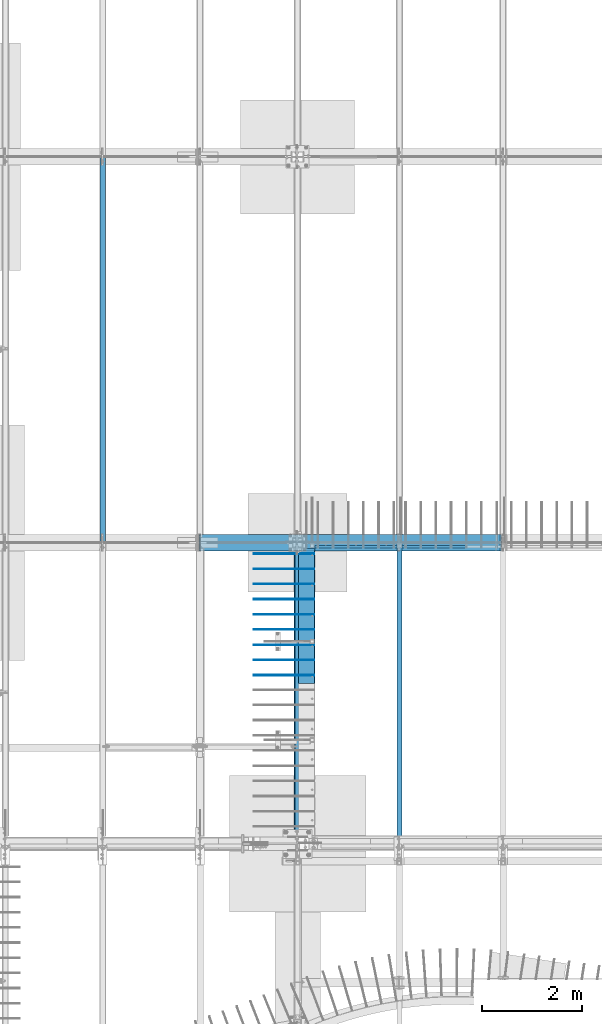
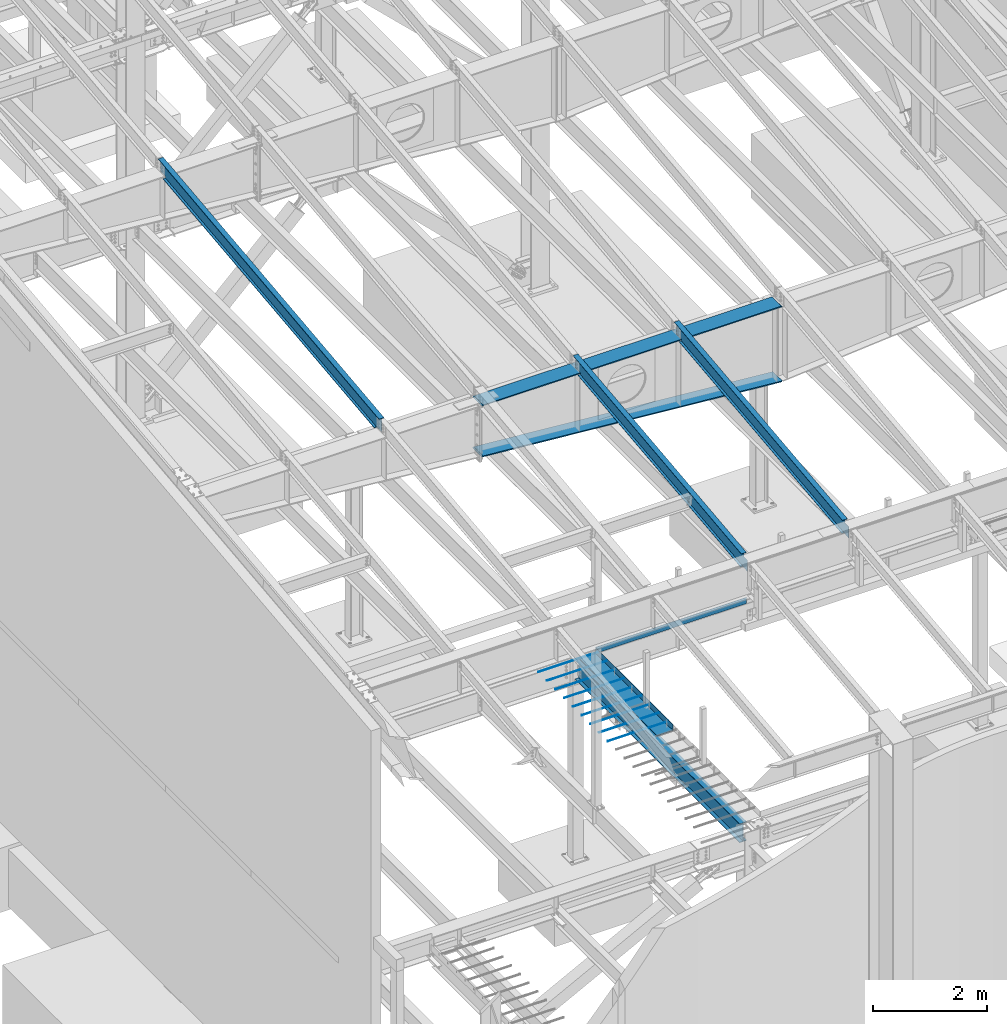
# One storey, part 710 of 1179: 17 beams, 15 elements without a shape of their own.
"""IFC2X3 building model written with IfcOpenShell, lengths in millimetres."""

from ifc_helpers import new_model, si_unit, frame, origin_with_axes, place, context, subcontext, project, spatial, faceted_brep, material, type_object, element, aggregate, save


model = new_model("IFC2X3")

# Units and contexts
model_context = context("Model", 3, precision=1e-05, world=origin_with_axes())
body_context = subcontext(model_context, "Body", "Model", "MODEL_VIEW")
ifc_project = project(units=[si_unit("LENGTHUNIT", "METRE", prefix="MILLI"), si_unit("AREAUNIT", "SQUARE_METRE"), si_unit("VOLUMEUNIT", "CUBIC_METRE"), si_unit("MASSUNIT", "GRAM", prefix="KILO"), si_unit("TIMEUNIT", "SECOND"), si_unit("PLANEANGLEUNIT", "RADIAN"), si_unit("SOLIDANGLEUNIT", "STERADIAN"), si_unit("THERMODYNAMICTEMPERATUREUNIT", "DEGREE_CELSIUS"), si_unit("LUMINOUSINTENSITYUNIT", "LUMEN")], contexts=[model_context])

# Site, building, storey
site_placement = place(None, origin_with_axes())
site = spatial("IfcSite", under=ifc_project, at=site_placement, CompositionType="ELEMENT")
building_placement = place(site_placement, origin_with_axes())
building = spatial("IfcBuilding", under=site, at=building_placement, Name="Undefined", CompositionType="ELEMENT")
storey_placement = place(building_placement, origin_with_axes())
storey = spatial("IfcBuildingStorey", under=building, at=storey_placement, Name="Undefined", CompositionType="ELEMENT", Elevation=0.0)

# Assembly, beam
assembly_1_placement = place(storey_placement, origin_with_axes())
assembly_1 = element("IfcElementAssembly", 1, at=assembly_1_placement, inside=storey, Name="BEAM", AssemblyPlace="NOTDEFINED", PredefinedType="RIGID_FRAME")
ifc_material_1 = material(Name="STEEL/A36")
beam_type_1 = type_object("IfcBeamType", PredefinedType="NOTDEFINED")
beam_1_placement = place(assembly_1_placement, frame((10150.475, 11372.85, 4235.45000610352), z_axis=(1.0, 0.0, 0.0), x_axis=(0.0, 0.0, -1.0)))
beam_1 = element("IfcBeam", 2, at=beam_1_placement, type_object=beam_type_1, material=ifc_material_1, Name="BENT_PLATE", context=body_context, shape_type="Brep", body=[
    faceted_brep([(133.350006103517, 47.6249992370613, 123.824999999997), (127.000006103516, 47.6249992370613, 123.824999999997), (127.000006103516, 3.17499999999927, 123.824999999997), (133.350006103517, 3.17499965729257, 123.824999999997), (133.350006103517, 3.17499965729257, 225.424999999999), (127.000006103516, 3.17499999999927, 225.424999999999), (127.000006103516, 47.6249992370613, 225.424999999999), (133.350006103517, 47.6249992370613, 225.424999999999), (0.0, 3.17499999999927, 123.824999999997), (0.0, 3.17499999999927, -1524.0), (0.0, -3.17499999999927, -1524.0), (6.00266503170133e-10, -3.17499999922438, 1524.00000000052), (6.00266503170133e-10, 3.17500000077416, 1524.00000000052), (0.0, 3.17499999999927, 225.424999999999), (133.350006103517, -3.17499999999927, -1524.0), (127.000006103516, 3.17499999999927, -1524.0), (127.000006103516, 47.6249992370613, -1524.0), (133.350006103517, 47.6249992370613, -1524.0), (133.350006103517, -3.17499999999927, 1524.0), (127.000006103516, 3.17499999999927, 1524.0), (133.350006103517, 47.6249992370613, 1524.0), (127.000006103516, 47.6249992370613, 1524.0)], [[[0, 1, 2, 3]], [[4, 5, 6, 7]], [[3, 2, 5, 4]], [[8, 9, 10, 11, 12, 13]], [[14, 10, 9, 15, 16, 17]], [[11, 10, 14, 18]], [[19, 12, 11, 18, 20, 21]], [[21, 20, 7, 6]], [[19, 21, 6, 5]], [[9, 8, 13, 12, 19, 5, 2, 15]], [[16, 15, 2, 1]], [[17, 16, 1, 0]], [[20, 18, 14, 17, 0, 3, 4, 7]]]),
])
aggregate(assembly_1, [beam_1])

assembly_2_placement = place(storey_placement, origin_with_axes())
assembly_2 = element("IfcElementAssembly", 3, at=assembly_2_placement, inside=storey, Name="BEAM", AssemblyPlace="NOTDEFINED", PredefinedType="RIGID_FRAME")
ifc_material_2 = material(Name="STEEL/A992")
beam_type_2 = type_object("IfcBeamType", Name="W12X14", PredefinedType="NOTDEFINED")
beam_2_placement = place(assembly_2_placement, frame((10325.1, 5452.54317924679, 9711.23798851527), z_axis=(0.0, -0.112284087038017, 0.993676146336441), x_axis=(0.0, 0.993676146336441, 0.112284087038017)))
beam_2 = element("IfcBeam", 4, at=beam_2_placement, type_object=beam_type_2, material=ifc_material_2, Name="BEAM", ObjectType="W12X14", context=body_context, shape_type="Brep", body=[
    faceted_brep([(-14.1944481268274, -2.38125000000036, -144.462499999927), (-14.9119897074661, -2.38115214811296, -150.812499999925), (137.488001223044, -2.38117577009325, -150.8125), (137.488001223013, -2.38125000000036, -144.462500000003), (137.48799371822, -50.7999999999993, -144.462500000005), (137.487993718216, -50.7999999999993, -150.812500000002), (5871.37503272929, 50.7999999999993, -144.462500002917), (5870.65749114864, 50.7999999999993, -150.812500002912), (137.488009517103, 50.7999999999993, -150.812500000002), (137.488009517107, 50.7999999999993, -144.462500000003), (137.488002012233, 2.3811758245356, -144.462500001737), (137.488002012265, 2.38132415558357, -150.812500000002), (-14.9119897074661, 2.38134777762207, -150.812499999925), (-14.1944481268274, 2.38125000000036, -144.462499999927), (5871.37503272928, 2.38124783346939, -144.462500002968), (6076.55490468175, 2.38124999999854, 144.462499996846), (6076.55490468175, 50.7999999999993, 144.462499996846), (6077.27244626239, 50.7999999999993, 150.812499996842), (6077.27244626239, -50.7999999999993, 150.812499996842), (6076.55490468175, -50.7999999999993, 144.462499996846), (6076.55490468175, -2.38124999999854, 144.462499996846), (6045.98095926941, -2.38124999999854, -126.106563095373), (6045.98095929506, 2.38124999999854, -126.10656309827), (5888.24414721426, -2.38124999999854, -108.282512497075), (5888.24414721426, 2.38122772319184, -108.282512497075), (5883.30625374162, -2.38124999999854, -108.697419370077), (5883.30625374162, 2.38122766974266, -108.697419370077), (5878.90301301472, -2.38124999999854, -110.970393360541), (5878.90301301472, 2.38122737693629, -110.970393360541), (5875.70477851863, -2.38124999999854, -114.755394783042), (5875.70477851863, 2.38122688934163, -114.755394783042), (5874.19845246322, -2.38124999999854, -119.476191482236), (5874.19845246322, 2.38122628119891, -119.476191482236), (5871.37503272929, -2.38124999999854, -144.462500002917), (5871.37503272929, -50.7999999999993, -144.462500002917), (5870.65749114864, -50.7999999999993, -150.812500002912), (-13.929041623056, -2.38125000000036, -142.113742318956), (12.2064158412222, -2.38125000000036, 89.176205714708), (12.2064158412222, 2.38125000000036, 89.176205714708), (-13.9290290466961, 2.38125000000036, -142.113631022425), (125.78359955719, -2.38125000000036, 76.342134544826), (125.78359955719, 2.38125000000036, 76.342134544826), (130.721493030343, -2.38125000000036, 76.7570414172296), (130.721493030343, 2.38125000000036, 76.7570414172296), (135.124733757862, -2.38125000000036, 79.0300154074976), (135.124733757862, 2.38125000000036, 79.0300154074976), (138.322968254461, -2.38125000000036, 82.8150168301745), (138.322968254461, 2.38125000000036, 82.8150168301745), (139.829294310099, -2.38125000000036, 87.5358135297793), (139.829294310099, 2.38125000000036, 87.5358135297793), (146.26193440305, 2.38125000000036, 144.46249999986), (146.26193440305, 50.7999999999993, 144.46249999986), (146.979475983694, 50.7999999999993, 150.812499999854), (146.979475983694, -50.7999999999993, 150.812499999854), (146.26193440305, -50.7999999999993, 144.46249999986), (146.26193440305, -2.38125000000036, 144.46249999986)], [[[0, 1, 2, 3]], [[4, 3, 2, 5]], [[6, 7, 8, 9]], [[10, 11, 12, 13]], [[9, 8, 11, 10]], [[14, 6, 9, 10]], [[15, 16, 17, 18, 19, 20, 21, 22]], [[21, 23, 24, 22]], [[25, 26, 24, 23]], [[27, 28, 26, 25]], [[29, 30, 28, 27]], [[31, 32, 30, 29]], [[33, 34, 35, 7, 6, 14, 32, 31]], [[35, 34, 4, 5]], [[1, 12, 11, 8, 7, 35, 5, 2]], [[36, 37, 38, 39, 13, 12, 1, 0]], [[40, 41, 38, 37]], [[42, 43, 41, 40]], [[44, 45, 43, 42]], [[46, 47, 45, 44]], [[48, 49, 47, 46]], [[15, 22, 24, 26, 28, 30, 32, 14, 10, 13, 39, 38, 41, 43, 45, 47, 49, 50]], [[16, 15, 50, 51]], [[17, 16, 51, 52]], [[18, 17, 52, 53]], [[19, 18, 53, 54]], [[20, 19, 54, 55]], [[53, 52, 51, 50, 49, 48, 55, 54]], [[46, 44, 42, 40, 37, 36, 0, 3, 33, 31, 29, 27, 25, 23, 21, 20, 55, 48]], [[34, 33, 3, 4]]]),
])
aggregate(assembly_2, [beam_2])

assembly_3_placement = place(storey_placement, origin_with_axes())
assembly_3 = element("IfcElementAssembly", 5, at=assembly_3_placement, inside=storey, Name="BEAM", AssemblyPlace="NOTDEFINED", PredefinedType="RIGID_FRAME")
beam_3_placement = place(assembly_3_placement, frame((8280.4, 5452.5431792468, 9711.23798851528), z_axis=(0.0, -0.112284087038017, 0.993676146336441), x_axis=(0.0, 0.993676146336441, 0.112284087038017)))
beam_3 = element("IfcBeam", 6, at=beam_3_placement, type_object=beam_type_2, material=ifc_material_2, Name="BEAM", ObjectType="W12X14", context=body_context, shape_type="Brep", body=[
    faceted_brep([(-14.1944481268274, -2.38125000000036, -144.462499999927), (-14.9119897074661, -2.38115214811296, -150.812499999925), (137.488001223044, -2.38117577009325, -150.8125), (137.488001223013, -2.38125000000036, -144.462500000003), (137.48799371822, -50.7999999999993, -144.462500000005), (137.487993718216, -50.7999999999993, -150.812500000002), (5871.37503272929, 50.7999999999993, -144.462500002917), (5870.65749114864, 50.7999999999993, -150.812500002912), (137.488009517103, 50.7999999999993, -150.812500000002), (137.488009517107, 50.7999999999993, -144.462500000003), (137.488002012233, 2.3811758245356, -144.462500001737), (137.488002012265, 2.38132415558357, -150.812500000002), (-14.9119897074661, 2.38134777762207, -150.812499999925), (-14.1944481268274, 2.38125000000036, -144.462499999927), (5871.37503272928, 2.38124783346939, -144.462500002968), (6076.55490468175, 2.38124999999854, 144.462499996846), (6076.55490468175, 50.7999999999993, 144.462499996846), (6077.27244626239, 50.7999999999993, 150.812499996842), (6077.27244626239, -50.7999999999993, 150.812499996842), (6076.55490468175, -50.7999999999993, 144.462499996846), (6076.55490468175, -2.38124999999854, 144.462499996846), (6045.98095926941, -2.38124999999854, -126.106563095373), (6045.98095929506, 2.38124999999854, -126.10656309827), (5888.24414721426, -2.38124999999854, -108.282512497075), (5888.24414721426, 2.38122772319184, -108.282512497075), (5883.30625374162, -2.38124999999854, -108.697419370077), (5883.30625374162, 2.38122766974266, -108.697419370077), (5878.90301301472, -2.38124999999854, -110.970393360541), (5878.90301301472, 2.38122737693629, -110.970393360541), (5875.70477851863, -2.38124999999854, -114.755394783042), (5875.70477851863, 2.38122688934163, -114.755394783042), (5874.19845246322, -2.38124999999854, -119.476191482236), (5874.19845246322, 2.38122628119891, -119.476191482236), (5871.37503272929, -2.38124999999854, -144.462500002917), (5871.37503272929, -50.7999999999993, -144.462500002917), (5870.65749114864, -50.7999999999993, -150.812500002912), (-13.929041623056, -2.38125000000036, -142.113742318956), (12.2064158412222, -2.38125000000036, 89.176205714708), (12.2064158412222, 2.38125000000036, 89.176205714708), (-13.9290290466961, 2.38125000000036, -142.113631022425), (125.78359955719, -2.38125000000036, 76.342134544826), (125.78359955719, 2.38125000000036, 76.342134544826), (130.721493030343, -2.38125000000036, 76.7570414172296), (130.721493030343, 2.38125000000036, 76.7570414172296), (135.124733757862, -2.38125000000036, 79.0300154074976), (135.124733757862, 2.38125000000036, 79.0300154074976), (138.322968254461, -2.38125000000036, 82.8150168301745), (138.322968254461, 2.38125000000036, 82.8150168301745), (139.829294310099, -2.38125000000036, 87.5358135297793), (139.829294310099, 2.38125000000036, 87.5358135297793), (146.26193440305, 2.38125000000036, 144.46249999986), (146.26193440305, 50.7999999999993, 144.46249999986), (146.979475983694, 50.7999999999993, 150.812499999854), (146.979475983694, -50.7999999999993, 150.812499999854), (146.26193440305, -50.7999999999993, 144.46249999986), (146.26193440305, -2.38125000000036, 144.46249999986)], [[[0, 1, 2, 3]], [[4, 3, 2, 5]], [[6, 7, 8, 9]], [[10, 11, 12, 13]], [[9, 8, 11, 10]], [[14, 6, 9, 10]], [[15, 16, 17, 18, 19, 20, 21, 22]], [[21, 23, 24, 22]], [[25, 26, 24, 23]], [[27, 28, 26, 25]], [[29, 30, 28, 27]], [[31, 32, 30, 29]], [[33, 34, 35, 7, 6, 14, 32, 31]], [[35, 34, 4, 5]], [[1, 12, 11, 8, 7, 35, 5, 2]], [[36, 37, 38, 39, 13, 12, 1, 0]], [[40, 41, 38, 37]], [[42, 43, 41, 40]], [[44, 45, 43, 42]], [[46, 47, 45, 44]], [[48, 49, 47, 46]], [[15, 22, 24, 26, 28, 30, 32, 14, 10, 13, 39, 38, 41, 43, 45, 47, 49, 50]], [[16, 15, 50, 51]], [[17, 16, 51, 52]], [[18, 17, 52, 53]], [[19, 18, 53, 54]], [[20, 19, 54, 55]], [[53, 52, 51, 50, 49, 48, 55, 54]], [[46, 44, 42, 40, 37, 36, 0, 3, 33, 31, 29, 27, 25, 23, 21, 20, 55, 48]], [[34, 33, 3, 4]]]),
])
aggregate(assembly_3, [beam_3])

assembly_4_placement = place(storey_placement, origin_with_axes())
assembly_4 = element("IfcElementAssembly", 7, at=assembly_4_placement, inside=storey, Name="BEAM", AssemblyPlace="NOTDEFINED", PredefinedType="RIGID_FRAME")
beam_type_3 = type_object("IfcBeamType", Name="W16X31", PredefinedType="NOTDEFINED")
beam_4_placement = place(assembly_4_placement, frame((8280.4, 5429.25, 3900.4875), z_axis=(0.0, 0.0, 1.0), x_axis=(0.0, 1.0, 0.0)))
beam_4 = element("IfcBeam", 8, at=beam_4_placement, type_object=beam_type_3, material=ifc_material_2, Name="BEAM", ObjectType="W16X31", context=body_context, shape_type="Brep", body=[
    faceted_brep([(174.624999999998, -69.8500000000004, -190.5), (174.624999999998, -69.8500000000004, -201.6125), (5937.25, -69.8499999999985, -201.6125), (5937.25, -69.8499999999985, -190.5), (174.624999999998, -3.17499999999927, -190.5), (5937.25, -3.17499999999927, -190.5), (174.624999999998, -3.17499999999927, 190.5), (5937.25, -3.17499999999927, 190.5), (174.624999999998, -69.8500000000004, 190.5), (5937.25, -69.8499999999985, 190.5), (174.624999999998, -69.8500000000004, 201.6125), (5937.25, -69.8499999999985, 201.6125), (174.624999999998, 69.8500000000004, 201.6125), (5937.25, 69.8499999999985, 201.6125), (174.624999999998, 69.8500000000004, 190.5), (5937.25, 69.8499999999985, 190.5), (174.624999999998, 3.17499999999927, 190.5), (5937.25, 3.17499999999927, 190.5), (174.624999999998, 3.17499999999927, -190.5), (5937.25, 3.17499999999927, -190.5), (174.624999999998, 69.8500000000004, -190.5), (5937.25, 69.8499999999985, -190.5), (174.624999999998, 69.8500000000004, -201.6125), (5937.25, 69.8499999999985, -201.6125)], [[[0, 1, 2, 3]], [[4, 0, 3, 5]], [[6, 4, 5, 7]], [[8, 6, 7, 9]], [[10, 8, 9, 11]], [[12, 10, 11, 13]], [[14, 12, 13, 15]], [[16, 14, 15, 17]], [[18, 16, 17, 19]], [[20, 18, 19, 21]], [[1, 0, 4, 6, 8, 10, 12, 14, 16, 18, 20, 22]], [[1, 22, 23, 2]], [[19, 17, 15, 13, 11, 9, 7, 5, 3, 2, 23, 21]], [[22, 20, 21, 23]]]),
])

# Assembly, beams
assembly_5_placement = place(storey_placement, origin_with_axes())
assembly_5 = element("IfcElementAssembly", 9, at=assembly_5_placement, inside=storey, Name="RAFTER BEAM", AssemblyPlace="NOTDEFINED", PredefinedType="RIGID_FRAME")
beam_type_4 = type_object("IfcBeamType", PredefinedType="NOTDEFINED")
beam_5_placement = place(assembly_5_placement, frame((6272.85711370745, 11480.8093353655, 9156.761430532), z_axis=(0.0, 1.0, 0.0), x_axis=(0.996393807714311, 0.0, -0.0848491599756718)))
beam_5 = element("IfcBeam", 10, at=beam_5_placement, type_object=beam_type_4, material=ifc_material_1, Name="PLATE", context=body_context, shape_type="Brep", body=[
    faceted_brep([(6118.06175688711, -11.1260574296557, 165.1), (6118.06324270278, -11.1125000015909, -165.1), (6099.33128163823, 11.1124999984149, -165.1), (6099.33128163823, 11.1124999984149, 165.1), (46.0705669150266, -11.1125236432727, 165.1), (27.3845310142515, 11.112499999992, 165.1), (27.3845310142515, 11.112499999992, -165.1), (46.0705669150275, -11.1125000000138, -165.1)], [[[0, 1, 2, 3]], [[4, 5, 6, 7]], [[5, 4, 0, 3]], [[6, 5, 3, 2]], [[7, 6, 2, 1]], [[4, 7, 1, 0]]]),
])
beam_6_placement = place(assembly_5_placement, frame((6273.8, 11480.8093353614, 10240.98385672), z_axis=(0.0, -1.0, 0.0), x_axis=(1.0, 0.0, 0.0)))
beam_6 = element("IfcBeam", 11, at=beam_6_placement, type_object=beam_type_4, material=ifc_material_1, Name="PLATE", context=body_context, shape_type="Brep", body=[
    faceted_brep([(47.6250003814685, 11.1125003814705, 165.1), (47.6250003814685, 11.1124999999993, -165.1), (25.3999999999987, -11.1124999999993, -165.1), (25.3999999999987, -11.1124999999993, 165.1), (6096.0, -11.1124999999993, 165.1), (6096.0, -11.1124999999993, -165.1), (6073.77499961853, 11.1124999999993, -165.1), (6073.77499961853, 11.1124999999993, 165.1)], [[[0, 1, 2, 3]], [[4, 5, 6, 7]], [[4, 7, 0, 3]], [[5, 4, 3, 2]], [[6, 5, 2, 1]], [[7, 6, 1, 0]]]),
])
aggregate(assembly_5, [beam_5, beam_6])

# Assembly, beam
assembly_6_placement = place(storey_placement, origin_with_axes())
assembly_6 = element("IfcElementAssembly", 12, at=assembly_6_placement, inside=storey, Name="#4 DOWEL", AssemblyPlace="NOTDEFINED", PredefinedType="NOTDEFINED")
ifc_material_3 = material(Name="REBAR/A615-40")
beam_type_5 = type_object("IfcBeamType", Name="#4 DOWEL", PredefinedType="NOTDEFINED")
beam_7_placement = place(assembly_6_placement, frame((7400.925, 11258.55, 4203.70000610352), z_axis=(0.0, 0.0, 1.0), x_axis=(1.0, 0.0, 0.0)))
beam_7 = element("IfcBeam", 13, at=beam_7_placement, type_object=beam_type_5, material=ifc_material_3, Name="#4 DOWEL", ObjectType="#4 DOWEL", context=body_context, shape_type="Brep", body=[
    faceted_brep([(0.0, -6.34999999999854, 0.0), (0.0, -4.49012806053361, -4.49012806053452), (1219.2, -4.49012806053543, -4.49012806053452), (1219.2, -6.35000000000036, 0.0), (0.0, 0.0, -6.34999999999991), (1219.2, 0.0, -6.35000000000036), (0.0, 4.49012806053361, -4.49012806053452), (1219.2, 4.49012806053543, -4.49012806053452), (0.0, 6.34999999999854, 0.0), (1219.2, 6.35000000000036, 0.0), (0.0, 4.49012806053361, 4.49012806053452), (1219.2, 4.49012806053543, 4.49012806053452), (0.0, 0.0, 6.34999999999991), (1219.2, 0.0, 6.35000000000036), (0.0, -4.49012806053361, 4.49012806053452), (1219.2, -4.49012806053543, 4.49012806053452)], [[[0, 1, 2, 3]], [[1, 4, 5, 2]], [[4, 6, 7, 5]], [[6, 8, 9, 7]], [[8, 10, 11, 9]], [[10, 12, 13, 11]], [[12, 14, 15, 13]], [[14, 0, 3, 15]], [[5, 7, 9, 11, 13, 15, 3, 2]], [[14, 12, 10, 8, 6, 4, 1, 0]]]),
])
aggregate(assembly_6, [beam_7])

assembly_7_placement = place(storey_placement, origin_with_axes())
assembly_7 = element("IfcElementAssembly", 14, at=assembly_7_placement, inside=storey, Name="#4 DOWEL", AssemblyPlace="NOTDEFINED", PredefinedType="NOTDEFINED")
beam_8_placement = place(assembly_7_placement, frame((7400.925, 10953.75, 4203.70000610352), z_axis=(0.0, 0.0, 1.0), x_axis=(1.0, 0.0, 0.0)))
beam_8 = element("IfcBeam", 15, at=beam_8_placement, type_object=beam_type_5, material=ifc_material_3, Name="#4 DOWEL", ObjectType="#4 DOWEL", context=body_context, shape_type="Brep", body=[
    faceted_brep([(0.0, -6.34999999999854, 0.0), (0.0, -4.49012806053361, -4.49012806053452), (1219.2, -4.49012806053543, -4.49012806053452), (1219.2, -6.35000000000036, 0.0), (0.0, 0.0, -6.34999999999991), (1219.2, 0.0, -6.35000000000036), (0.0, 4.49012806053361, -4.49012806053452), (1219.2, 4.49012806053543, -4.49012806053452), (0.0, 6.34999999999854, 0.0), (1219.2, 6.35000000000036, 0.0), (0.0, 4.49012806053361, 4.49012806053452), (1219.2, 4.49012806053543, 4.49012806053452), (0.0, 0.0, 6.34999999999991), (1219.2, 0.0, 6.35000000000036), (0.0, -4.49012806053361, 4.49012806053452), (1219.2, -4.49012806053543, 4.49012806053452)], [[[0, 1, 2, 3]], [[1, 4, 5, 2]], [[4, 6, 7, 5]], [[6, 8, 9, 7]], [[8, 10, 11, 9]], [[10, 12, 13, 11]], [[12, 14, 15, 13]], [[14, 0, 3, 15]], [[5, 7, 9, 11, 13, 15, 3, 2]], [[14, 12, 10, 8, 6, 4, 1, 0]]]),
])
aggregate(assembly_7, [beam_8])

assembly_8_placement = place(storey_placement, origin_with_axes())
assembly_8 = element("IfcElementAssembly", 16, at=assembly_8_placement, inside=storey, Name="#4 DOWEL", AssemblyPlace="NOTDEFINED", PredefinedType="NOTDEFINED")
beam_9_placement = place(assembly_8_placement, frame((7400.925, 10648.95, 4203.70000610352), z_axis=(0.0, 0.0, 1.0), x_axis=(1.0, 0.0, 0.0)))
beam_9 = element("IfcBeam", 17, at=beam_9_placement, type_object=beam_type_5, material=ifc_material_3, Name="#4 DOWEL", ObjectType="#4 DOWEL", context=body_context, shape_type="Brep", body=[
    faceted_brep([(0.0, -6.34999999999854, 0.0), (0.0, -4.49012806053361, -4.49012806053452), (1219.2, -4.49012806053543, -4.49012806053452), (1219.2, -6.35000000000036, 0.0), (0.0, 0.0, -6.34999999999991), (1219.2, 0.0, -6.35000000000036), (0.0, 4.49012806053361, -4.49012806053452), (1219.2, 4.49012806053543, -4.49012806053452), (0.0, 6.34999999999854, 0.0), (1219.2, 6.35000000000036, 0.0), (0.0, 4.49012806053361, 4.49012806053452), (1219.2, 4.49012806053543, 4.49012806053452), (0.0, 0.0, 6.34999999999991), (1219.2, 0.0, 6.35000000000036), (0.0, -4.49012806053361, 4.49012806053452), (1219.2, -4.49012806053543, 4.49012806053452)], [[[0, 1, 2, 3]], [[1, 4, 5, 2]], [[4, 6, 7, 5]], [[6, 8, 9, 7]], [[8, 10, 11, 9]], [[10, 12, 13, 11]], [[12, 14, 15, 13]], [[14, 0, 3, 15]], [[5, 7, 9, 11, 13, 15, 3, 2]], [[14, 12, 10, 8, 6, 4, 1, 0]]]),
])
aggregate(assembly_8, [beam_9])

assembly_9_placement = place(storey_placement, origin_with_axes())
assembly_9 = element("IfcElementAssembly", 18, at=assembly_9_placement, inside=storey, Name="#4 DOWEL", AssemblyPlace="NOTDEFINED", PredefinedType="NOTDEFINED")
beam_10_placement = place(assembly_9_placement, frame((7400.925, 10344.15, 4203.70000610352), z_axis=(0.0, 0.0, 1.0), x_axis=(1.0, 0.0, 0.0)))
beam_10 = element("IfcBeam", 19, at=beam_10_placement, type_object=beam_type_5, material=ifc_material_3, Name="#4 DOWEL", ObjectType="#4 DOWEL", context=body_context, shape_type="Brep", body=[
    faceted_brep([(0.0, -6.34999999999854, 0.0), (0.0, -4.49012806053361, -4.49012806053452), (1219.2, -4.49012806053543, -4.49012806053452), (1219.2, -6.35000000000036, 0.0), (0.0, 0.0, -6.34999999999991), (1219.2, 0.0, -6.35000000000036), (0.0, 4.49012806053361, -4.49012806053452), (1219.2, 4.49012806053543, -4.49012806053452), (0.0, 6.34999999999854, 0.0), (1219.2, 6.35000000000036, 0.0), (0.0, 4.49012806053361, 4.49012806053452), (1219.2, 4.49012806053543, 4.49012806053452), (0.0, 0.0, 6.34999999999991), (1219.2, 0.0, 6.35000000000036), (0.0, -4.49012806053361, 4.49012806053452), (1219.2, -4.49012806053543, 4.49012806053452)], [[[0, 1, 2, 3]], [[1, 4, 5, 2]], [[4, 6, 7, 5]], [[6, 8, 9, 7]], [[8, 10, 11, 9]], [[10, 12, 13, 11]], [[12, 14, 15, 13]], [[14, 0, 3, 15]], [[5, 7, 9, 11, 13, 15, 3, 2]], [[14, 12, 10, 8, 6, 4, 1, 0]]]),
])
aggregate(assembly_9, [beam_10])

assembly_10_placement = place(storey_placement, origin_with_axes())
assembly_10 = element("IfcElementAssembly", 20, at=assembly_10_placement, inside=storey, Name="#4 DOWEL", AssemblyPlace="NOTDEFINED", PredefinedType="NOTDEFINED")
beam_11_placement = place(assembly_10_placement, frame((7400.925, 10039.35, 4203.70000610352), z_axis=(0.0, 0.0, 1.0), x_axis=(1.0, 0.0, 0.0)))
beam_11 = element("IfcBeam", 21, at=beam_11_placement, type_object=beam_type_5, material=ifc_material_3, Name="#4 DOWEL", ObjectType="#4 DOWEL", context=body_context, shape_type="Brep", body=[
    faceted_brep([(0.0, -6.34999999999854, 0.0), (0.0, -4.49012806053361, -4.49012806053452), (1219.2, -4.49012806053543, -4.49012806053452), (1219.2, -6.35000000000036, 0.0), (0.0, 0.0, -6.34999999999991), (1219.2, 0.0, -6.35000000000036), (0.0, 4.49012806053361, -4.49012806053452), (1219.2, 4.49012806053543, -4.49012806053452), (0.0, 6.34999999999854, 0.0), (1219.2, 6.35000000000036, 0.0), (0.0, 4.49012806053361, 4.49012806053452), (1219.2, 4.49012806053543, 4.49012806053452), (0.0, 0.0, 6.34999999999991), (1219.2, 0.0, 6.35000000000036), (0.0, -4.49012806053361, 4.49012806053452), (1219.2, -4.49012806053543, 4.49012806053452)], [[[0, 1, 2, 3]], [[1, 4, 5, 2]], [[4, 6, 7, 5]], [[6, 8, 9, 7]], [[8, 10, 11, 9]], [[10, 12, 13, 11]], [[12, 14, 15, 13]], [[14, 0, 3, 15]], [[5, 7, 9, 11, 13, 15, 3, 2]], [[14, 12, 10, 8, 6, 4, 1, 0]]]),
])
aggregate(assembly_10, [beam_11])

assembly_11_placement = place(storey_placement, origin_with_axes())
assembly_11 = element("IfcElementAssembly", 22, at=assembly_11_placement, inside=storey, Name="#4 DOWEL", AssemblyPlace="NOTDEFINED", PredefinedType="NOTDEFINED")
beam_12_placement = place(assembly_11_placement, frame((7400.925, 9734.55, 4203.70000610352), z_axis=(0.0, 0.0, 1.0), x_axis=(1.0, 0.0, 0.0)))
beam_12 = element("IfcBeam", 23, at=beam_12_placement, type_object=beam_type_5, material=ifc_material_3, Name="#4 DOWEL", ObjectType="#4 DOWEL", context=body_context, shape_type="Brep", body=[
    faceted_brep([(0.0, -6.34999999999854, 0.0), (0.0, -4.49012806053361, -4.49012806053452), (1219.2, -4.49012806053543, -4.49012806053452), (1219.2, -6.35000000000036, 0.0), (0.0, 0.0, -6.34999999999991), (1219.2, 0.0, -6.35000000000036), (0.0, 4.49012806053361, -4.49012806053452), (1219.2, 4.49012806053543, -4.49012806053452), (0.0, 6.34999999999854, 0.0), (1219.2, 6.35000000000036, 0.0), (0.0, 4.49012806053361, 4.49012806053452), (1219.2, 4.49012806053543, 4.49012806053452), (0.0, 0.0, 6.34999999999991), (1219.2, 0.0, 6.35000000000036), (0.0, -4.49012806053361, 4.49012806053452), (1219.2, -4.49012806053543, 4.49012806053452)], [[[0, 1, 2, 3]], [[1, 4, 5, 2]], [[4, 6, 7, 5]], [[6, 8, 9, 7]], [[8, 10, 11, 9]], [[10, 12, 13, 11]], [[12, 14, 15, 13]], [[14, 0, 3, 15]], [[5, 7, 9, 11, 13, 15, 3, 2]], [[14, 12, 10, 8, 6, 4, 1, 0]]]),
])
aggregate(assembly_11, [beam_12])

assembly_12_placement = place(storey_placement, origin_with_axes())
assembly_12 = element("IfcElementAssembly", 24, at=assembly_12_placement, inside=storey, Name="#4 DOWEL", AssemblyPlace="NOTDEFINED", PredefinedType="NOTDEFINED")
beam_13_placement = place(assembly_12_placement, frame((7400.925, 9429.75, 4203.70000610352), z_axis=(0.0, 0.0, 1.0), x_axis=(1.0, 0.0, 0.0)))
beam_13 = element("IfcBeam", 25, at=beam_13_placement, type_object=beam_type_5, material=ifc_material_3, Name="#4 DOWEL", ObjectType="#4 DOWEL", context=body_context, shape_type="Brep", body=[
    faceted_brep([(0.0, -6.34999999999854, 0.0), (0.0, -4.49012806053361, -4.49012806053452), (1219.2, -4.49012806053543, -4.49012806053452), (1219.2, -6.35000000000036, 0.0), (0.0, 0.0, -6.34999999999991), (1219.2, 0.0, -6.35000000000036), (0.0, 4.49012806053361, -4.49012806053452), (1219.2, 4.49012806053543, -4.49012806053452), (0.0, 6.34999999999854, 0.0), (1219.2, 6.35000000000036, 0.0), (0.0, 4.49012806053361, 4.49012806053452), (1219.2, 4.49012806053543, 4.49012806053452), (0.0, 0.0, 6.34999999999991), (1219.2, 0.0, 6.35000000000036), (0.0, -4.49012806053361, 4.49012806053452), (1219.2, -4.49012806053543, 4.49012806053452)], [[[0, 1, 2, 3]], [[1, 4, 5, 2]], [[4, 6, 7, 5]], [[6, 8, 9, 7]], [[8, 10, 11, 9]], [[10, 12, 13, 11]], [[12, 14, 15, 13]], [[14, 0, 3, 15]], [[5, 7, 9, 11, 13, 15, 3, 2]], [[14, 12, 10, 8, 6, 4, 1, 0]]]),
])
aggregate(assembly_12, [beam_13])

assembly_13_placement = place(storey_placement, origin_with_axes())
assembly_13 = element("IfcElementAssembly", 26, at=assembly_13_placement, inside=storey, Name="#4 DOWEL", AssemblyPlace="NOTDEFINED", PredefinedType="NOTDEFINED")
beam_14_placement = place(assembly_13_placement, frame((7400.925, 9124.95, 4203.70000610352), z_axis=(0.0, 0.0, 1.0), x_axis=(1.0, 0.0, 0.0)))
beam_14 = element("IfcBeam", 27, at=beam_14_placement, type_object=beam_type_5, material=ifc_material_3, Name="#4 DOWEL", ObjectType="#4 DOWEL", context=body_context, shape_type="Brep", body=[
    faceted_brep([(0.0, -6.34999999999854, 0.0), (0.0, -4.49012806053361, -4.49012806053452), (1219.2, -4.49012806053543, -4.49012806053452), (1219.2, -6.35000000000036, 0.0), (0.0, 0.0, -6.34999999999991), (1219.2, 0.0, -6.35000000000036), (0.0, 4.49012806053361, -4.49012806053452), (1219.2, 4.49012806053543, -4.49012806053452), (0.0, 6.34999999999854, 0.0), (1219.2, 6.35000000000036, 0.0), (0.0, 4.49012806053361, 4.49012806053452), (1219.2, 4.49012806053543, 4.49012806053452), (0.0, 0.0, 6.34999999999991), (1219.2, 0.0, 6.35000000000036), (0.0, -4.49012806053361, 4.49012806053452), (1219.2, -4.49012806053543, 4.49012806053452)], [[[0, 1, 2, 3]], [[1, 4, 5, 2]], [[4, 6, 7, 5]], [[6, 8, 9, 7]], [[8, 10, 11, 9]], [[10, 12, 13, 11]], [[12, 14, 15, 13]], [[14, 0, 3, 15]], [[5, 7, 9, 11, 13, 15, 3, 2]], [[14, 12, 10, 8, 6, 4, 1, 0]]]),
])
aggregate(assembly_13, [beam_14])

assembly_14_placement = place(storey_placement, origin_with_axes())
assembly_14 = element("IfcElementAssembly", 28, at=assembly_14_placement, inside=storey, Name="#4 DOWEL", AssemblyPlace="NOTDEFINED", PredefinedType="NOTDEFINED")
beam_15_placement = place(assembly_14_placement, frame((7400.925, 8820.15, 4203.70000610352), z_axis=(0.0, 0.0, 1.0), x_axis=(1.0, 0.0, 0.0)))
beam_15 = element("IfcBeam", 29, at=beam_15_placement, type_object=beam_type_5, material=ifc_material_3, Name="#4 DOWEL", ObjectType="#4 DOWEL", context=body_context, shape_type="Brep", body=[
    faceted_brep([(0.0, -6.34999999999854, 0.0), (0.0, -4.49012806053361, -4.49012806053452), (1219.2, -4.49012806053543, -4.49012806053452), (1219.2, -6.35000000000036, 0.0), (0.0, 0.0, -6.34999999999991), (1219.2, 0.0, -6.35000000000036), (0.0, 4.49012806053361, -4.49012806053452), (1219.2, 4.49012806053543, -4.49012806053452), (0.0, 6.34999999999854, 0.0), (1219.2, 6.35000000000036, 0.0), (0.0, 4.49012806053361, 4.49012806053452), (1219.2, 4.49012806053543, 4.49012806053452), (0.0, 0.0, 6.34999999999991), (1219.2, 0.0, 6.35000000000036), (0.0, -4.49012806053361, 4.49012806053452), (1219.2, -4.49012806053543, 4.49012806053452)], [[[0, 1, 2, 3]], [[1, 4, 5, 2]], [[4, 6, 7, 5]], [[6, 8, 9, 7]], [[8, 10, 11, 9]], [[10, 12, 13, 11]], [[12, 14, 15, 13]], [[14, 0, 3, 15]], [[5, 7, 9, 11, 13, 15, 3, 2]], [[14, 12, 10, 8, 6, 4, 1, 0]]]),
])
aggregate(assembly_14, [beam_15])

# Beam
beam_type_6 = type_object("IfcBeamType", PredefinedType="NOTDEFINED")
beam_16_placement = place(assembly_4_placement, frame((8296.27498779297, 10009.1875, 4105.275), z_axis=(0.0, -1.0, 0.0), x_axis=(1.0, 0.0, 0.0)))
beam_16 = element("IfcBeam", 30, at=beam_16_placement, type_object=beam_type_6, material=ifc_material_1, Name="BENT_PLATE", context=body_context, shape_type="Brep", body=[
    faceted_brep([(0.0, -3.17500000000018, -1357.3125), (0.0, -3.17500000000018, 1357.3125), (0.0, 3.17500000000018, 1357.3125), (0.0, 3.17500000000018, -1357.3125), (323.850012207031, 3.17500000000018, 1357.3125), (323.850012207031, 3.17500000000018, -1357.3125), (330.200012207029, -3.17500000000018, -1357.3125), (330.200012207029, -3.17500000000018, 1357.3125), (323.850012207031, 130.175006103515, 1357.3125), (323.850012207031, 130.175006103515, -1357.3125), (330.200012207029, 130.175006103515, 1357.3125), (330.200012207029, 130.175006103515, -1357.3125)], [[[0, 1, 2, 3]], [[3, 2, 4, 5]], [[1, 0, 6, 7]], [[5, 4, 8, 9]], [[4, 2, 1, 7, 10, 8]], [[7, 6, 11, 10]], [[6, 0, 3, 5, 9, 11]], [[10, 11, 9, 8]]]),
])

aggregate(assembly_4, [beam_16, beam_4])

# Assembly, beam
assembly_15_placement = place(storey_placement, origin_with_axes())
assembly_15 = element("IfcElementAssembly", 31, at=assembly_15_placement, inside=storey, Name="BEAM", AssemblyPlace="NOTDEFINED", PredefinedType="RIGID_FRAME")
beam_type_7 = type_object("IfcBeamType", Name="W12X22", PredefinedType="NOTDEFINED")
beam_17_placement = place(assembly_15_placement, frame((4368.8, 11498.2779321842, 10389.6051906331), z_axis=(0.0, -0.112284087038017, 0.993676146336441), x_axis=(0.0, 0.993676146336441, 0.112284087038017)))
beam_17 = element("IfcBeam", 32, at=beam_17_placement, type_object=beam_type_7, material=ifc_material_2, Name="BEAM", ObjectType="W12X22", context=body_context, shape_type="Brep", body=[
    faceted_brep([(7583.46730043383, -3.17499999999927, -144.462500002994), (7583.46730043383, -50.7999999999993, -144.462500002994), (7582.21160266769, -50.7999999999993, -155.575000002988), (7582.21160266769, 50.7999999999993, -155.575000002988), (7583.46730043383, 50.7999999999993, -144.462500002994), (7583.46730043383, 3.17499999999927, -144.462500002994), (7586.83832669432, 3.17499999999927, -114.630059163946), (7586.83832669432, -3.17499999999927, -114.630059163946), (7588.34465274973, 3.17499999999927, -109.909262464753), (7588.34465274973, -3.17499999999927, -109.909262464753), (7591.54288724583, 3.17499999999927, -106.124261042249), (7591.54288724583, -3.17499999999927, -106.124261042249), (7595.94612797272, 3.17499999999927, -103.851287051781), (7595.94612797272, -3.17499999999927, -103.851287051781), (7600.88402144536, 3.17499999999927, -103.436380178771), (7600.88402144536, -3.17499999999927, -103.436380178771), (7758.6208335002, -3.17499999999927, -121.260430776909), (7758.62083354224, 3.17499999999927, -121.26043078166), (6.38101702707718, -50.7999999999993, 155.574999999912), (5.12531926095107, -50.7999999999993, 144.46249999992), (7788.64717240277, -50.7999999999993, 144.462499996762), (7789.9028701689, -50.7999999999993, 155.574999996754), (6.38101702707718, 50.7999999999993, 155.574999999912), (7789.9028701689, 50.7999999999993, 155.574999996754), (5.12531926095107, 50.7999999999993, 144.46249999992), (7788.64717240277, 50.7999999999993, 144.462499996762), (5.12531926095107, 3.17499999999927, 144.46249999992), (7788.64717240277, 3.17499999999927, 144.462499996762), (145.30344487597, -3.17499999999927, -142.022226300664), (145.30344487597, 3.17499999999927, -142.022226300664), (145.027696926005, 3.17499999999927, -144.462499999976), (145.027696926005, 50.7999999999993, -144.462499999976), (143.771999161854, 50.7999999999993, -155.574999999972), (143.771999161854, -50.7999999999993, -155.574999999972), (145.027696926005, -50.7999999999993, -144.462499999976), (145.027696926005, -3.17499999999927, -144.462499999976), (-25.0716067072917, -3.17499999999927, -122.770071196437), (-25.0716067072917, 3.17499999999927, -122.770071196437), (5.12531926095107, -3.17499999999927, 144.46249999992), (7788.64717240277, -3.17499999999927, 144.462499996762)], [[[0, 1, 2, 3, 4, 5, 6, 7]], [[7, 6, 8, 9]], [[9, 8, 10, 11]], [[11, 10, 12, 13]], [[13, 12, 14, 15]], [[16, 15, 14, 17]], [[18, 19, 20, 21]], [[22, 18, 21, 23]], [[24, 22, 23, 25]], [[26, 24, 25, 27]], [[28, 29, 30, 31, 32, 33, 34, 35]], [[36, 37, 29, 28]], [[38, 19, 18, 22, 24, 26, 37, 36]], [[19, 38, 39, 20]], [[27, 25, 23, 21, 20, 39, 16, 17]], [[12, 10, 8, 6, 5, 30, 29, 37, 26, 27, 17, 14]], [[31, 30, 5, 4]], [[32, 31, 4, 3]], [[33, 32, 3, 2]], [[34, 33, 2, 1]], [[35, 34, 1, 0]], [[39, 38, 36, 28, 35, 0, 7, 9, 11, 13, 15, 16]]]),
])
aggregate(assembly_15, [beam_17])

save(model, "model.ifc")
